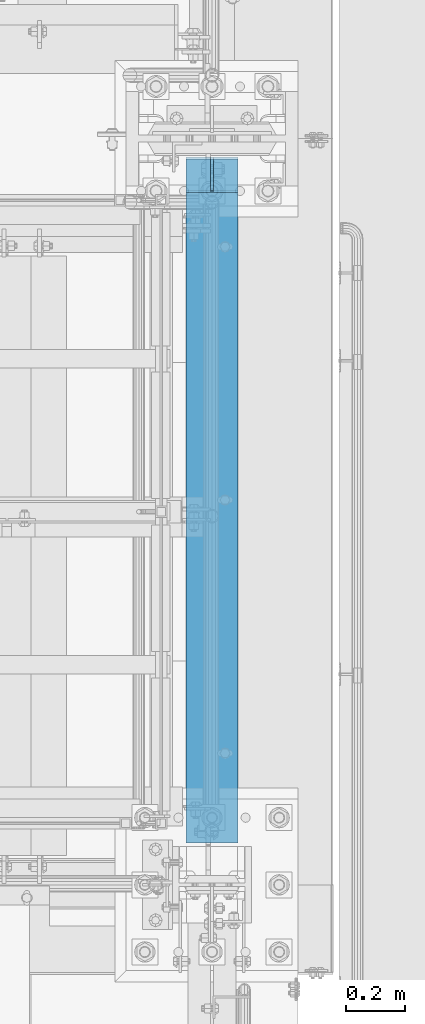
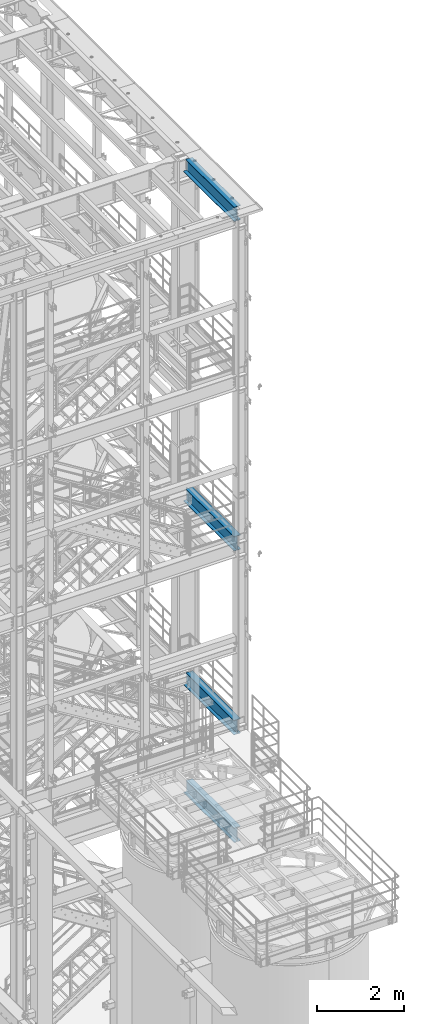
# One storey, part 1003 of 1876: 4 beams, 4 elements without a shape of their own.
"""IFC2X3 building model written with IfcOpenShell, lengths in millimetres."""

import ifcopenshell
import ifcopenshell.guid

model = None  # the IFC model being written
_history = None  # IfcOwnerHistory: only IFC2X3 demands one
_inside = {}  # id of a spatial element -> (the spatial element, [elements in it])
_under = {}  # id of a project, library or spatial element -> (it, [spatial elements below it])
_declared = {}  # id of a project -> (the project, [libraries it declares])
_typed = {}  # id of a type object -> (the type object, [elements of that type])
_made_of = {}  # id of a material, layer set ... -> (it, [elements and type objects made of it])


def new_model(schema):
    """Start an empty IFC model of exactly this schema.

    Asked for "IFC4X3", IfcOpenShell would pick the latest addendum, in which some entities
    have other attributes; the version numbers below select the first issue.
    IFC2X3 requires an IfcOwnerHistory on every rooted entity: one is made here for all.
    """
    global model, _history
    if schema == "IFC4X3":
        model = ifcopenshell.file(schema_version=(4, 3, 0, 0))
    else:
        model = ifcopenshell.file(schema=schema)
    _inside.clear()
    _under.clear()
    _declared.clear()
    _typed.clear()
    _made_of.clear()
    _history = None
    if model.schema == "IFC2X3":
        org = make("IfcOrganization", Name="unknown")
        user = make(
            "IfcPersonAndOrganization",
            ThePerson=make("IfcPerson", FamilyName="unknown"),
            TheOrganization=org,
        )
        app = make(
            "IfcApplication",
            ApplicationDeveloper=org,
            Version="unknown",
            ApplicationFullName="unknown",
            ApplicationIdentifier="unknown",
        )
        _history = make(
            "IfcOwnerHistory",
            OwningUser=user,
            OwningApplication=app,
            ChangeAction="ADDED",
            CreationDate=0,
        )
    return model


def make(cls, **values):
    """One entity of the class cls with the attributes given. An attribute that is None is left unset."""
    return model.create_entity(
        cls, **{name: value for name, value in values.items() if value is not None}
    )


def rooted(cls, **values):
    """An entity with a GlobalId (a new one), such as an element, a storey or a relation."""
    return make(cls, GlobalId=ifcopenshell.guid.new(), OwnerHistory=_history, **values)


def si_unit(unit_type, name, prefix=None):
    """IfcSIUnit, for example si_unit("LENGTHUNIT", "METRE", prefix="MILLI")."""
    return make("IfcSIUnit", UnitType=unit_type, Prefix=prefix, Name=name)


def assignment(units):
    """IfcUnitAssignment: the units of a project."""
    return None if units is None else make("IfcUnitAssignment", Units=units)


def point(xyz):
    """IfcCartesianPoint."""
    return None if xyz is None else make("IfcCartesianPoint", Coordinates=xyz)


def direction(xyz):
    """IfcDirection."""
    return None if xyz is None else make("IfcDirection", DirectionRatios=xyz)


def frame(location, z_axis=None, x_axis=None):
    """IfcAxis2Placement3D, a coordinate frame: its origin and axes. An axis left out is left unset."""
    return make(
        "IfcAxis2Placement3D",
        Location=point(location),
        Axis=direction(z_axis),
        RefDirection=direction(x_axis),
    )


def origin_with_axes():
    """The frame at (0, 0, 0) with the z axis (0, 0, 1) and the x axis (1, 0, 0) written out."""
    return frame((0.0, 0.0, 0.0), z_axis=(0.0, 0.0, 1.0), x_axis=(1.0, 0.0, 0.0))


def place(relative_to, where):
    """IfcLocalPlacement: puts the frame where relative to a parent placement (None: the world)."""
    return make(
        "IfcLocalPlacement", PlacementRelTo=relative_to, RelativePlacement=where
    )


def context(
    kind, dimensions, precision=None, world=None, true_north=None, identifier=None
):
    """IfcGeometricRepresentationContext, for example the 3D "Model" context."""
    return make(
        "IfcGeometricRepresentationContext",
        ContextIdentifier=identifier,
        ContextType=kind,
        CoordinateSpaceDimension=dimensions,
        Precision=precision,
        WorldCoordinateSystem=world,
        TrueNorth=true_north,
    )


def subcontext(parent, identifier, kind, view, scale=None):
    """IfcGeometricRepresentationSubContext, for example "Body" below "Model"."""
    return make(
        "IfcGeometricRepresentationSubContext",
        ContextIdentifier=identifier,
        ContextType=kind,
        ParentContext=parent,
        TargetScale=scale,
        TargetView=view,
    )


def project(units=None, contexts=None):
    """IfcProject with its units and contexts."""
    return rooted(
        "IfcProject",
        Name="project",
        RepresentationContexts=contexts,
        UnitsInContext=assignment(units),
    )


def spatial(cls, under=None, at=None, **own):
    """A site, building, storey or space (cls), placed at a placement, below another one or the project."""
    s = rooted(cls, ObjectPlacement=at, **own)
    if under is not None:
        _under.setdefault(under.id(), (under, []))[1].append(s)
    return s


def faces_of(points, faces, orient=None, outer=None):
    """IfcFace entities. A face is a list of loops; a loop is a list of indices into points, from 0.

    orient and outer hold one flag for each loop. By default every Orientation is true, the
    first loop of a face is its IfcFaceOuterBound and the others are IfcFaceBound.
    """
    made = []
    for i, loops in enumerate(faces):
        bounds = []
        for j, loop in enumerate(loops):
            is_outer = j == 0 if outer is None else outer[i][j]
            bounds.append(
                make(
                    "IfcFaceOuterBound" if is_outer else "IfcFaceBound",
                    Bound=make("IfcPolyLoop", Polygon=[points[k] for k in loop]),
                    Orientation=True if orient is None else orient[i][j],
                )
            )
        made.append(make("IfcFace", Bounds=bounds))
    return made


def faceted_brep(points, faces, orient=None, outer=None, voids=None):
    """IfcFacetedBrep: a solid bounded by flat faces; with voids (closed shells), ...WithVoids."""
    shared = [point(p) for p in points]
    hull = make("IfcClosedShell", CfsFaces=faces_of(shared, faces, orient, outer))
    if voids is None:
        return make("IfcFacetedBrep", Outer=hull)
    return make(
        "IfcFacetedBrepWithVoids",
        Outer=hull,
        Voids=[
            make(cls, CfsFaces=faces_of(shared, fs, o, b)) for cls, fs, o, b in voids
        ],
    )


def shape(context_of_items, identifier, shape_type, items):
    """IfcShapeRepresentation: the items that make up one representation, for example the "Body"."""
    return make(
        "IfcShapeRepresentation",
        ContextOfItems=context_of_items,
        RepresentationIdentifier=identifier,
        RepresentationType=shape_type,
        Items=items,
    )


def material(Name=None, Category=None):
    """IfcMaterial."""
    return make("IfcMaterial", Name=Name, Category=Category)


def made_of(thing, what):
    """Note that an element or type object is made of a material, layer set ...; save() writes the relation."""
    if what is not None:
        _made_of.setdefault(what.id(), (what, []))[1].append(thing)
    return thing


def type_object(cls, material=None, **own):
    """A type object (cls), such as IfcWallType, which elements share."""
    return made_of(rooted(cls, **own), material)


def element(
    cls,
    number,
    at=None,
    inside=None,
    cuts=None,
    type_object=None,
    material=None,
    context=None,
    identifier="Body",
    shape_type=None,
    held_by="IfcProductDefinitionShape",
    body=None,
    shapes=None,
    **own,
):
    """One element of the class cls, such as IfcWall. Its Tag is "e" and its number.

    at: its placement. inside: the storey or other place that contains it. cuts: it is an
    opening in that element (IfcRelVoidsElement). A single representation is given by context,
    identifier, shape_type and body (its items); several are given by shapes. held_by: the class
    of the entity that holds the representations. save() writes the other relations.
    """
    e = rooted(cls, Tag="e%d" % number, ObjectPlacement=at, **own)
    if body is not None:
        shapes = [shape(context, identifier, shape_type, body)]
    if shapes is not None:
        e.Representation = make(held_by, Representations=shapes)
    if inside is not None:
        _inside.setdefault(inside.id(), (inside, []))[1].append(e)
    if cuts is not None:
        rooted(
            "IfcRelVoidsElement", RelatingBuildingElement=cuts, RelatedOpeningElement=e
        )
    if type_object is not None:
        _typed.setdefault(type_object.id(), (type_object, []))[1].append(e)
    return made_of(e, material)


def aggregate(whole, parts):
    """IfcRelAggregates: a whole, such as a stair, and the parts it consists of."""
    return rooted("IfcRelAggregates", RelatingObject=whole, RelatedObjects=parts)


def save(model, path):
    """Write the relations noted so far, then the file.

    IfcRelAggregates (storeys below a building ...), IfcRelContainedInSpatialStructure (elements
    in a storey), IfcRelDefinesByType, IfcRelAssociatesMaterial and IfcRelDeclares: one each for
    every whole, place, type object, material and project.
    """
    for whole, parts in _under.values():
        aggregate(whole, parts)
    for where, things in _inside.values():
        rooted(
            "IfcRelContainedInSpatialStructure",
            RelatedElements=things,
            RelatingStructure=where,
        )
    for kind, things in _typed.values():
        rooted("IfcRelDefinesByType", RelatedObjects=things, RelatingType=kind)
    for what, things in _made_of.values():
        rooted("IfcRelAssociatesMaterial", RelatedObjects=things, RelatingMaterial=what)
    for by, libraries in _declared.values():
        rooted("IfcRelDeclares", RelatingContext=by, RelatedDefinitions=libraries)
    model.write(path)


model = new_model("IFC2X3")

# Units and contexts
model_context = context("Model", 3, precision=1e-05, world=origin_with_axes())
body_context = subcontext(model_context, "Body", "Model", "MODEL_VIEW")
ifc_project = project(units=[si_unit("LENGTHUNIT", "METRE", prefix="MILLI"), si_unit("AREAUNIT", "SQUARE_METRE"), si_unit("VOLUMEUNIT", "CUBIC_METRE"), si_unit("MASSUNIT", "GRAM", prefix="KILO"), si_unit("TIMEUNIT", "SECOND"), si_unit("PLANEANGLEUNIT", "RADIAN"), si_unit("SOLIDANGLEUNIT", "STERADIAN"), si_unit("THERMODYNAMICTEMPERATUREUNIT", "DEGREE_CELSIUS"), si_unit("LUMINOUSINTENSITYUNIT", "LUMEN")], contexts=[model_context])

# Site, building, storey
site_placement = place(None, origin_with_axes())
site = spatial("IfcSite", under=ifc_project, at=site_placement, CompositionType="ELEMENT")
building_placement = place(site_placement, origin_with_axes())
building = spatial("IfcBuilding", under=site, at=building_placement, Name="Undefined", CompositionType="ELEMENT")
storey_placement = place(building_placement, origin_with_axes())
storey = spatial("IfcBuildingStorey", under=building, at=storey_placement, Name="Undefined", CompositionType="ELEMENT", Elevation=0.0)

# Assembly, beam
assembly_1_placement = place(storey_placement, origin_with_axes())
assembly_1 = element("IfcElementAssembly", 1, at=assembly_1_placement, inside=storey, Name="BEAM", AssemblyPlace="NOTDEFINED", PredefinedType="RIGID_FRAME")
ifc_material = material(Name="STEEL/A992")
beam_type = type_object("IfcBeamType", Name="W16X45", PredefinedType="NOTDEFINED")
beam_1_placement = place(assembly_1_placement, frame((7620.0, -7112.0, 13104.8125), z_axis=(0.0, 0.0, 1.0), x_axis=(0.0, 1.0, 0.0)))
beam_1 = element("IfcBeam", 2, at=beam_1_placement, type_object=beam_type, material=ifc_material, Name="BEAM", ObjectType="W16X45", context=body_context, shape_type="Brep", body=[
    faceted_brep([(2362.99375, -88.8999999999996, 204.787499999999), (2362.99375, -88.8999999999996, 190.5), (2362.99375, -4.76249999999982, 190.5), (2362.99375, -4.76249999999982, 166.427501487731), (2362.99375, 4.76249999999982, 166.427501487731), (2362.99375, 4.76249999999982, 190.5), (2362.99375, 88.8999999999996, 190.5), (2362.99375, 88.8999999999996, 204.787499999999), (2363.96047992259, -4.76249999999982, 161.567421969685), (2363.96047992259, 4.76249999999982, 161.567421969685), (2366.71349382307, -4.76249999999982, 157.447245501531), (2366.71349382307, 4.76249999999982, 157.447245501531), (2370.83367029122, -4.76249999999982, 154.694231601054), (2370.83367029122, 4.76249999999982, 154.694231601054), (2375.69374980926, -4.76249999999982, 153.727501678466), (2375.69374980926, 4.76249999999982, 153.727501678466), (2477.29375, -4.76249999999982, 153.727501678466), (2477.29375, 4.76249999999982, 153.727501678466), (142.875, -88.8999999999996, -204.787499999999), (142.875, -88.8999999999996, -190.5), (142.875, -4.76249999999982, -190.5), (142.875, -4.76249999999982, 190.5), (142.875, -88.8999999999996, 190.5), (142.875, -88.8999999999996, 204.787499999999), (142.875, 88.8999999999996, 204.787499999999), (142.875, 88.8999999999996, 190.5), (142.875, 4.76249999999982, 190.5), (142.875, 4.76249999999982, -190.5), (142.875, 88.8999999999996, -190.5), (142.875, 88.8999999999996, -204.787499999999), (2477.29375, 4.76249999999982, -190.5), (2477.29375, 88.8999999999996, -190.5), (2477.29375, 88.8999999999996, -204.787499999999), (2477.29375, -88.8999999999996, -204.787499999999), (2477.29375, -88.8999999999996, -190.5), (2477.29375, -4.76249999999982, -190.5)], [[[0, 1, 2, 3, 4, 5, 6, 7]], [[8, 9, 4, 3]], [[10, 11, 9, 8]], [[12, 13, 11, 10]], [[14, 15, 13, 12]], [[16, 17, 15, 14]], [[18, 19, 20, 21, 22, 23, 24, 25, 26, 27, 28, 29]], [[28, 27, 30, 31]], [[29, 28, 31, 32]], [[18, 29, 32, 33]], [[19, 18, 33, 34]], [[20, 19, 34, 35]], [[12, 10, 8, 3, 2, 21, 20, 35, 16, 14]], [[22, 21, 2, 1]], [[23, 22, 1, 0]], [[24, 23, 0, 7]], [[25, 24, 7, 6]], [[26, 25, 6, 5]], [[30, 27, 26, 5, 4, 9, 11, 13, 15, 17]], [[35, 34, 33, 32, 31, 30, 17, 16]]]),
])
aggregate(assembly_1, [beam_1])

assembly_2_placement = place(storey_placement, origin_with_axes())
assembly_2 = element("IfcElementAssembly", 3, at=assembly_2_placement, inside=storey, Name="BEAM", AssemblyPlace="NOTDEFINED", PredefinedType="RIGID_FRAME")
beam_2_placement = place(assembly_2_placement, frame((7620.0, -7112.0, 7948.6125), z_axis=(0.0, 0.0, 1.0), x_axis=(0.0, 1.0, 0.0)))
beam_2 = element("IfcBeam", 4, at=beam_2_placement, type_object=beam_type, material=ifc_material, Name="BEAM", ObjectType="W16X45", context=body_context, shape_type="Brep", body=[
    faceted_brep([(2356.64375, -88.8999999999996, 204.7875), (2356.64375, -88.8999999999996, 190.5), (2356.64375, -4.76249999999982, 190.5), (2356.64375, -4.76249999999982, 153.727497673035), (2356.64375, 4.76249999999982, 153.727497673035), (2356.64375, 4.76249999999982, 190.5), (2356.64375, 88.8999999999996, 190.5), (2356.64375, 88.8999999999996, 204.7875), (2357.61047992259, -4.76249999999982, 148.86741815499), (2357.61047992259, 4.76249999999982, 148.86741815499), (2360.36349382307, -4.76249999999982, 144.747241686836), (2360.36349382307, 4.76249999999982, 144.747241686836), (2364.48367029122, -4.76249999999982, 141.994227786357), (2364.48367029122, 4.76249999999982, 141.994227786357), (2369.34374980926, -4.76249999999982, 141.02749786377), (2369.34374980926, 4.76249999999982, 141.02749786377), (2470.94375, -4.76249999999982, 141.02749786377), (2470.94375, 4.76249999999982, 141.02749786377), (142.875, -88.8999999999996, -204.787499999999), (142.875, -88.8999999999996, -190.5), (142.875, -4.76249999999982, -190.5), (142.875, -4.76249999999982, 190.5), (142.875, -88.8999999999996, 190.5), (142.875, -88.8999999999996, 204.787499999999), (142.875, 88.8999999999996, 204.787499999999), (142.875, 88.8999999999996, 190.5), (142.875, 4.76249999999982, 190.5), (142.875, 4.76249999999982, -190.5), (142.875, 88.8999999999996, -190.5), (142.875, 88.8999999999996, -204.787499999999), (2470.94375, 4.76249999999982, -190.5), (2470.94375, 88.8999999999996, -190.5), (2470.94375, 88.8999999999996, -204.7875), (2470.94375, -88.8999999999996, -204.7875), (2470.94375, -88.8999999999996, -190.5), (2470.94375, -4.76249999999982, -190.5)], [[[0, 1, 2, 3, 4, 5, 6, 7]], [[8, 9, 4, 3]], [[10, 11, 9, 8]], [[12, 13, 11, 10]], [[14, 15, 13, 12]], [[16, 17, 15, 14]], [[18, 19, 20, 21, 22, 23, 24, 25, 26, 27, 28, 29]], [[28, 27, 30, 31]], [[29, 28, 31, 32]], [[18, 29, 32, 33]], [[19, 18, 33, 34]], [[20, 19, 34, 35]], [[12, 10, 8, 3, 2, 21, 20, 35, 16, 14]], [[22, 21, 2, 1]], [[23, 22, 1, 0]], [[24, 23, 0, 7]], [[25, 24, 7, 6]], [[26, 25, 6, 5]], [[30, 27, 26, 5, 4, 9, 11, 13, 15, 17]], [[35, 34, 33, 32, 31, 30, 17, 16]]]),
])
aggregate(assembly_2, [beam_2])

assembly_3_placement = place(storey_placement, origin_with_axes())
assembly_3 = element("IfcElementAssembly", 5, at=assembly_3_placement, inside=storey, Name="BEAM", AssemblyPlace="NOTDEFINED", PredefinedType="RIGID_FRAME")
beam_3_placement = place(assembly_3_placement, frame((7620.0, -7112.0, 22350.4125), z_axis=(0.0, 0.0, 1.0), x_axis=(0.0, 1.0, 0.0)))
beam_3 = element("IfcBeam", 6, at=beam_3_placement, type_object=beam_type, material=ifc_material, Name="BEAM", ObjectType="W16X45", context=body_context, shape_type="Brep", body=[
    faceted_brep([(2362.99375, -88.8999999999996, 204.787499999999), (2362.99375, -88.8999999999996, 190.5), (2362.99375, -4.76249999999982, 190.5), (2362.99375, -4.76249999999982, 166.427501487731), (2362.99375, 4.76249999999982, 166.427501487731), (2362.99375, 4.76249999999982, 190.5), (2362.99375, 88.8999999999996, 190.5), (2362.99375, 88.8999999999996, 204.787499999999), (2363.96047992259, -4.76249999999982, 161.567421969685), (2363.96047992259, 4.76249999999982, 161.567421969685), (2366.71349382307, -4.76249999999982, 157.447245501531), (2366.71349382307, 4.76249999999982, 157.447245501531), (2370.83367029122, -4.76249999999982, 154.694231601054), (2370.83367029122, 4.76249999999982, 154.694231601054), (2375.69374980926, -4.76249999999982, 153.727501678466), (2375.69374980926, 4.76249999999982, 153.727501678466), (2477.29375, -4.76249999999982, 153.727501678466), (2477.29375, 4.76249999999982, 153.727501678466), (142.875, -88.8999999999996, -204.787499999999), (142.875, -88.8999999999996, -190.5), (142.875, -4.76249999999982, -190.5), (142.875, -4.76249999999982, 190.5), (142.875, -88.8999999999996, 190.5), (142.875, -88.8999999999996, 204.787499999999), (142.875, 88.8999999999996, 204.787499999999), (142.875, 88.8999999999996, 190.5), (142.875, 4.76249999999982, 190.5), (142.875, 4.76249999999982, -190.5), (142.875, 88.8999999999996, -190.5), (142.875, 88.8999999999996, -204.787499999999), (2477.29375, 4.76249999999982, -190.5), (2477.29375, 88.8999999999996, -190.5), (2477.29375, 88.8999999999996, -204.787499999999), (2477.29375, -88.8999999999996, -204.787499999999), (2477.29375, -88.8999999999996, -190.5), (2477.29375, -4.76249999999982, -190.5)], [[[0, 1, 2, 3, 4, 5, 6, 7]], [[8, 9, 4, 3]], [[10, 11, 9, 8]], [[12, 13, 11, 10]], [[14, 15, 13, 12]], [[16, 17, 15, 14]], [[18, 19, 20, 21, 22, 23, 24, 25, 26, 27, 28, 29]], [[28, 27, 30, 31]], [[29, 28, 31, 32]], [[18, 29, 32, 33]], [[19, 18, 33, 34]], [[20, 19, 34, 35]], [[12, 10, 8, 3, 2, 21, 20, 35, 16, 14]], [[22, 21, 2, 1]], [[23, 22, 1, 0]], [[24, 23, 0, 7]], [[25, 24, 7, 6]], [[26, 25, 6, 5]], [[30, 27, 26, 5, 4, 9, 11, 13, 15, 17]], [[35, 34, 33, 32, 31, 30, 17, 16]]]),
])
aggregate(assembly_3, [beam_3])

assembly_4_placement = place(storey_placement, origin_with_axes())
assembly_4 = element("IfcElementAssembly", 7, at=assembly_4_placement, inside=storey, Name="BEAM", AssemblyPlace="NOTDEFINED", PredefinedType="RIGID_FRAME")
beam_4_placement = place(assembly_4_placement, frame((7620.0, -7112.0, 4926.0125), z_axis=(0.0, 0.0, 1.0), x_axis=(0.0, 1.0, 0.0)))
beam_4 = element("IfcBeam", 8, at=beam_4_placement, type_object=beam_type, material=ifc_material, Name="BEAM", ObjectType="W16X45", context=body_context, shape_type="Brep", body=[
    faceted_brep([(2356.64375, -88.8999999999996, 204.7875), (2356.64375, -88.8999999999996, 190.5), (2356.64375, -4.76249999999982, 190.5), (2356.64375, -4.76249999999982, 153.727497673035), (2356.64375, 4.76249999999982, 153.727497673035), (2356.64375, 4.76249999999982, 190.5), (2356.64375, 88.8999999999996, 190.5), (2356.64375, 88.8999999999996, 204.7875), (2357.61047992259, -4.76249999999982, 148.86741815499), (2357.61047992259, 4.76249999999982, 148.86741815499), (2360.36349382307, -4.76249999999982, 144.747241686836), (2360.36349382307, 4.76249999999982, 144.747241686836), (2364.48367029122, -4.76249999999982, 141.994227786357), (2364.48367029122, 4.76249999999982, 141.994227786357), (2369.34374980926, -4.76249999999982, 141.02749786377), (2369.34374980926, 4.76249999999982, 141.02749786377), (2470.94375, -4.76249999999982, 141.02749786377), (2470.94375, 4.76249999999982, 141.02749786377), (142.875, -88.8999999999996, -204.787499999999), (142.875, -88.8999999999996, -190.5), (142.875, -4.76249999999982, -190.5), (142.875, -4.76249999999982, 190.5), (142.875, -88.8999999999996, 190.5), (142.875, -88.8999999999996, 204.787499999999), (142.875, 88.8999999999996, 204.787499999999), (142.875, 88.8999999999996, 190.5), (142.875, 4.76249999999982, 190.5), (142.875, 4.76249999999982, -190.5), (142.875, 88.8999999999996, -190.5), (142.875, 88.8999999999996, -204.787499999999), (2470.94375, 4.76249999999982, -190.5), (2470.94375, 88.8999999999996, -190.5), (2470.94375, 88.8999999999996, -204.7875), (2470.94375, -88.8999999999996, -204.7875), (2470.94375, -88.8999999999996, -190.5), (2470.94375, -4.76249999999982, -190.5)], [[[0, 1, 2, 3, 4, 5, 6, 7]], [[8, 9, 4, 3]], [[10, 11, 9, 8]], [[12, 13, 11, 10]], [[14, 15, 13, 12]], [[16, 17, 15, 14]], [[18, 19, 20, 21, 22, 23, 24, 25, 26, 27, 28, 29]], [[28, 27, 30, 31]], [[29, 28, 31, 32]], [[18, 29, 32, 33]], [[19, 18, 33, 34]], [[20, 19, 34, 35]], [[12, 10, 8, 3, 2, 21, 20, 35, 16, 14]], [[22, 21, 2, 1]], [[23, 22, 1, 0]], [[24, 23, 0, 7]], [[25, 24, 7, 6]], [[26, 25, 6, 5]], [[30, 27, 26, 5, 4, 9, 11, 13, 15, 17]], [[35, 34, 33, 32, 31, 30, 17, 16]]]),
])
aggregate(assembly_4, [beam_4])

save(model, "model.ifc")
